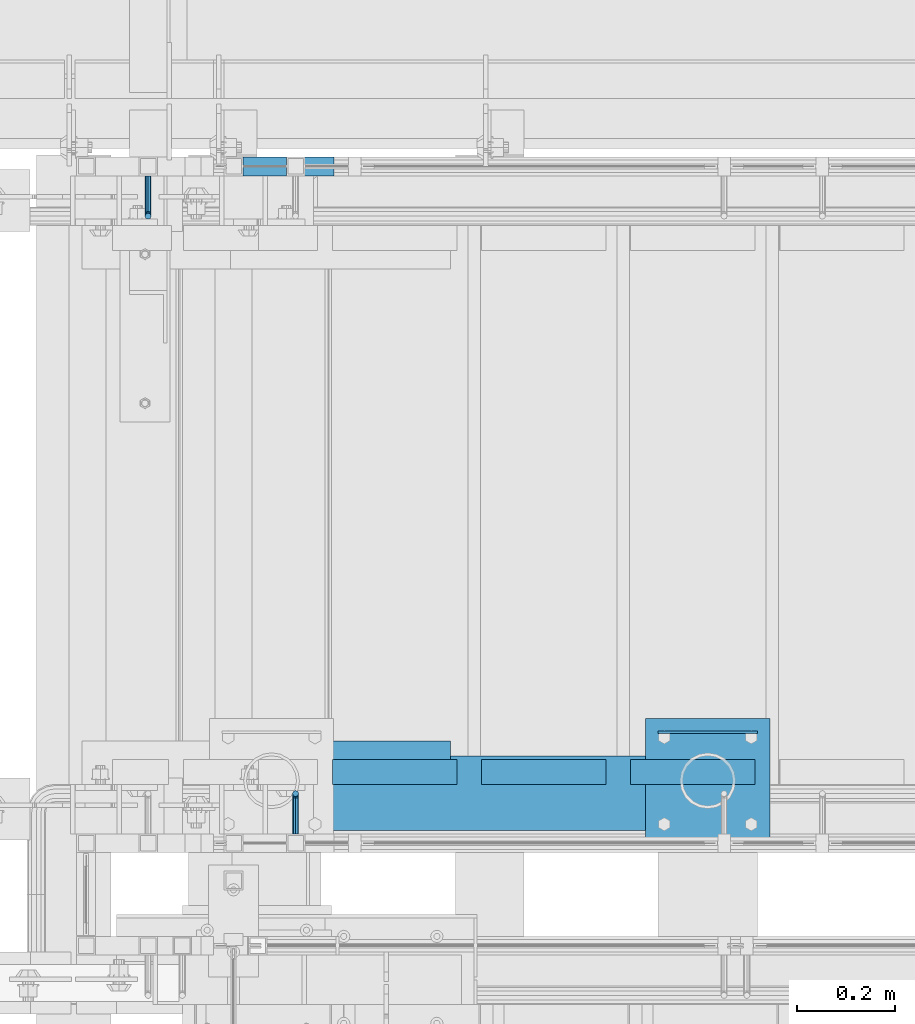
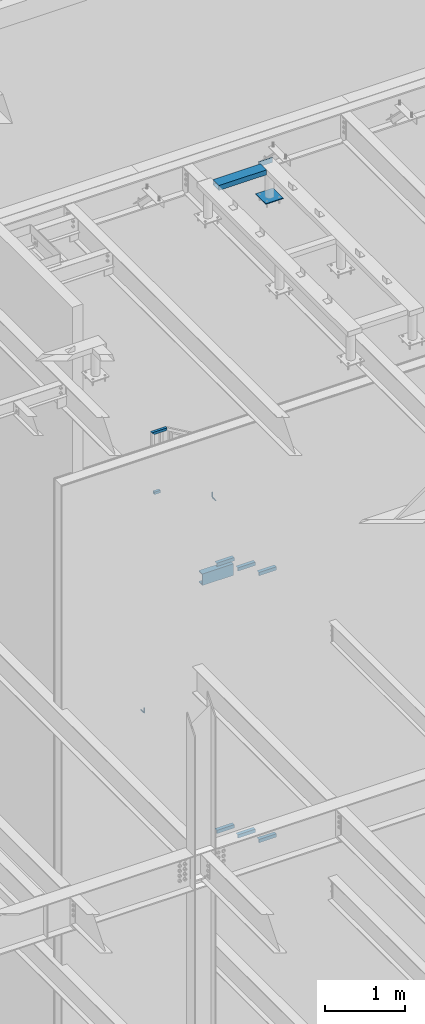
# One storey, part 933 of 1179: 12 beams, 2 members, 6 elements without a shape of their own.
"""IFC2X3 building model written with IfcOpenShell, lengths in millimetres."""

import ifcopenshell
import ifcopenshell.guid

model = None  # the IFC model being written
_history = None  # IfcOwnerHistory: only IFC2X3 demands one
_inside = {}  # id of a spatial element -> (the spatial element, [elements in it])
_under = {}  # id of a project, library or spatial element -> (it, [spatial elements below it])
_declared = {}  # id of a project -> (the project, [libraries it declares])
_typed = {}  # id of a type object -> (the type object, [elements of that type])
_made_of = {}  # id of a material, layer set ... -> (it, [elements and type objects made of it])


def new_model(schema):
    """Start an empty IFC model of exactly this schema.

    Asked for "IFC4X3", IfcOpenShell would pick the latest addendum, in which some entities
    have other attributes; the version numbers below select the first issue.
    IFC2X3 requires an IfcOwnerHistory on every rooted entity: one is made here for all.
    """
    global model, _history
    if schema == "IFC4X3":
        model = ifcopenshell.file(schema_version=(4, 3, 0, 0))
    else:
        model = ifcopenshell.file(schema=schema)
    _inside.clear()
    _under.clear()
    _declared.clear()
    _typed.clear()
    _made_of.clear()
    _history = None
    if model.schema == "IFC2X3":
        org = make("IfcOrganization", Name="unknown")
        user = make(
            "IfcPersonAndOrganization",
            ThePerson=make("IfcPerson", FamilyName="unknown"),
            TheOrganization=org,
        )
        app = make(
            "IfcApplication",
            ApplicationDeveloper=org,
            Version="unknown",
            ApplicationFullName="unknown",
            ApplicationIdentifier="unknown",
        )
        _history = make(
            "IfcOwnerHistory",
            OwningUser=user,
            OwningApplication=app,
            ChangeAction="ADDED",
            CreationDate=0,
        )
    return model


def make(cls, **values):
    """One entity of the class cls with the attributes given. An attribute that is None is left unset."""
    return model.create_entity(
        cls, **{name: value for name, value in values.items() if value is not None}
    )


def rooted(cls, **values):
    """An entity with a GlobalId (a new one), such as an element, a storey or a relation."""
    return make(cls, GlobalId=ifcopenshell.guid.new(), OwnerHistory=_history, **values)


def si_unit(unit_type, name, prefix=None):
    """IfcSIUnit, for example si_unit("LENGTHUNIT", "METRE", prefix="MILLI")."""
    return make("IfcSIUnit", UnitType=unit_type, Prefix=prefix, Name=name)


def assignment(units):
    """IfcUnitAssignment: the units of a project."""
    return None if units is None else make("IfcUnitAssignment", Units=units)


def point(xyz):
    """IfcCartesianPoint."""
    return None if xyz is None else make("IfcCartesianPoint", Coordinates=xyz)


def direction(xyz):
    """IfcDirection."""
    return None if xyz is None else make("IfcDirection", DirectionRatios=xyz)


def frame(location, z_axis=None, x_axis=None):
    """IfcAxis2Placement3D, a coordinate frame: its origin and axes. An axis left out is left unset."""
    return make(
        "IfcAxis2Placement3D",
        Location=point(location),
        Axis=direction(z_axis),
        RefDirection=direction(x_axis),
    )


def origin_with_axes():
    """The frame at (0, 0, 0) with the z axis (0, 0, 1) and the x axis (1, 0, 0) written out."""
    return frame((0.0, 0.0, 0.0), z_axis=(0.0, 0.0, 1.0), x_axis=(1.0, 0.0, 0.0))


def place(relative_to, where):
    """IfcLocalPlacement: puts the frame where relative to a parent placement (None: the world)."""
    return make(
        "IfcLocalPlacement", PlacementRelTo=relative_to, RelativePlacement=where
    )


def context(
    kind, dimensions, precision=None, world=None, true_north=None, identifier=None
):
    """IfcGeometricRepresentationContext, for example the 3D "Model" context."""
    return make(
        "IfcGeometricRepresentationContext",
        ContextIdentifier=identifier,
        ContextType=kind,
        CoordinateSpaceDimension=dimensions,
        Precision=precision,
        WorldCoordinateSystem=world,
        TrueNorth=true_north,
    )


def subcontext(parent, identifier, kind, view, scale=None):
    """IfcGeometricRepresentationSubContext, for example "Body" below "Model"."""
    return make(
        "IfcGeometricRepresentationSubContext",
        ContextIdentifier=identifier,
        ContextType=kind,
        ParentContext=parent,
        TargetScale=scale,
        TargetView=view,
    )


def project(units=None, contexts=None):
    """IfcProject with its units and contexts."""
    return rooted(
        "IfcProject",
        Name="project",
        RepresentationContexts=contexts,
        UnitsInContext=assignment(units),
    )


def spatial(cls, under=None, at=None, **own):
    """A site, building, storey or space (cls), placed at a placement, below another one or the project."""
    s = rooted(cls, ObjectPlacement=at, **own)
    if under is not None:
        _under.setdefault(under.id(), (under, []))[1].append(s)
    return s


def faces_of(points, faces, orient=None, outer=None):
    """IfcFace entities. A face is a list of loops; a loop is a list of indices into points, from 0.

    orient and outer hold one flag for each loop. By default every Orientation is true, the
    first loop of a face is its IfcFaceOuterBound and the others are IfcFaceBound.
    """
    made = []
    for i, loops in enumerate(faces):
        bounds = []
        for j, loop in enumerate(loops):
            is_outer = j == 0 if outer is None else outer[i][j]
            bounds.append(
                make(
                    "IfcFaceOuterBound" if is_outer else "IfcFaceBound",
                    Bound=make("IfcPolyLoop", Polygon=[points[k] for k in loop]),
                    Orientation=True if orient is None else orient[i][j],
                )
            )
        made.append(make("IfcFace", Bounds=bounds))
    return made


def faceted_brep(points, faces, orient=None, outer=None, voids=None):
    """IfcFacetedBrep: a solid bounded by flat faces; with voids (closed shells), ...WithVoids."""
    shared = [point(p) for p in points]
    hull = make("IfcClosedShell", CfsFaces=faces_of(shared, faces, orient, outer))
    if voids is None:
        return make("IfcFacetedBrep", Outer=hull)
    return make(
        "IfcFacetedBrepWithVoids",
        Outer=hull,
        Voids=[
            make(cls, CfsFaces=faces_of(shared, fs, o, b)) for cls, fs, o, b in voids
        ],
    )


def shape(context_of_items, identifier, shape_type, items):
    """IfcShapeRepresentation: the items that make up one representation, for example the "Body"."""
    return make(
        "IfcShapeRepresentation",
        ContextOfItems=context_of_items,
        RepresentationIdentifier=identifier,
        RepresentationType=shape_type,
        Items=items,
    )


def material(Name=None, Category=None):
    """IfcMaterial."""
    return make("IfcMaterial", Name=Name, Category=Category)


def made_of(thing, what):
    """Note that an element or type object is made of a material, layer set ...; save() writes the relation."""
    if what is not None:
        _made_of.setdefault(what.id(), (what, []))[1].append(thing)
    return thing


def type_object(cls, material=None, **own):
    """A type object (cls), such as IfcWallType, which elements share."""
    return made_of(rooted(cls, **own), material)


def element(
    cls,
    number,
    at=None,
    inside=None,
    cuts=None,
    type_object=None,
    material=None,
    context=None,
    identifier="Body",
    shape_type=None,
    held_by="IfcProductDefinitionShape",
    body=None,
    shapes=None,
    **own,
):
    """One element of the class cls, such as IfcWall. Its Tag is "e" and its number.

    at: its placement. inside: the storey or other place that contains it. cuts: it is an
    opening in that element (IfcRelVoidsElement). A single representation is given by context,
    identifier, shape_type and body (its items); several are given by shapes. held_by: the class
    of the entity that holds the representations. save() writes the other relations.
    """
    e = rooted(cls, Tag="e%d" % number, ObjectPlacement=at, **own)
    if body is not None:
        shapes = [shape(context, identifier, shape_type, body)]
    if shapes is not None:
        e.Representation = make(held_by, Representations=shapes)
    if inside is not None:
        _inside.setdefault(inside.id(), (inside, []))[1].append(e)
    if cuts is not None:
        rooted(
            "IfcRelVoidsElement", RelatingBuildingElement=cuts, RelatedOpeningElement=e
        )
    if type_object is not None:
        _typed.setdefault(type_object.id(), (type_object, []))[1].append(e)
    return made_of(e, material)


def aggregate(whole, parts):
    """IfcRelAggregates: a whole, such as a stair, and the parts it consists of."""
    return rooted("IfcRelAggregates", RelatingObject=whole, RelatedObjects=parts)


def save(model, path):
    """Write the relations noted so far, then the file.

    IfcRelAggregates (storeys below a building ...), IfcRelContainedInSpatialStructure (elements
    in a storey), IfcRelDefinesByType, IfcRelAssociatesMaterial and IfcRelDeclares: one each for
    every whole, place, type object, material and project.
    """
    for whole, parts in _under.values():
        aggregate(whole, parts)
    for where, things in _inside.values():
        rooted(
            "IfcRelContainedInSpatialStructure",
            RelatedElements=things,
            RelatingStructure=where,
        )
    for kind, things in _typed.values():
        rooted("IfcRelDefinesByType", RelatedObjects=things, RelatingType=kind)
    for what, things in _made_of.values():
        rooted("IfcRelAssociatesMaterial", RelatedObjects=things, RelatingMaterial=what)
    for by, libraries in _declared.values():
        rooted("IfcRelDeclares", RelatingContext=by, RelatedDefinitions=libraries)
    model.write(path)


model = new_model("IFC2X3")

# Units and contexts
model_context = context("Model", 3, precision=1e-05, world=origin_with_axes())
body_context = subcontext(model_context, "Body", "Model", "MODEL_VIEW")
ifc_project = project(units=[si_unit("LENGTHUNIT", "METRE", prefix="MILLI"), si_unit("AREAUNIT", "SQUARE_METRE"), si_unit("VOLUMEUNIT", "CUBIC_METRE"), si_unit("MASSUNIT", "GRAM", prefix="KILO"), si_unit("TIMEUNIT", "SECOND"), si_unit("PLANEANGLEUNIT", "RADIAN"), si_unit("SOLIDANGLEUNIT", "STERADIAN"), si_unit("THERMODYNAMICTEMPERATUREUNIT", "DEGREE_CELSIUS"), si_unit("LUMINOUSINTENSITYUNIT", "LUMEN")], contexts=[model_context])

# Site, building, storey
site_placement = place(None, origin_with_axes())
site = spatial("IfcSite", under=ifc_project, at=site_placement, CompositionType="ELEMENT")
building_placement = place(site_placement, origin_with_axes())
building = spatial("IfcBuilding", under=site, at=building_placement, Name="Undefined", CompositionType="ELEMENT")
storey_placement = place(building_placement, origin_with_axes())
storey = spatial("IfcBuildingStorey", under=building, at=storey_placement, Name="Undefined", CompositionType="ELEMENT", Elevation=0.0)

# Assembly, members
assembly_1_placement = place(storey_placement, origin_with_axes())
assembly_1 = element("IfcElementAssembly", 1, at=assembly_1_placement, inside=storey, Name="GUARDRAIL", AssemblyPlace="NOTDEFINED", PredefinedType="RIGID_FRAME")
ifc_material_1 = material()
member_type = type_object("IfcMemberType", Name="HSS1-1/2X1-1/2X1/8", PredefinedType="NOTDEFINED")
member_1_placement = place(assembly_1_placement, frame((19605.6249994667, 41065.449999238, 8293.0999995645), z_axis=(0.0, -1.0, 0.0), x_axis=(1.0, 0.0, 0.0)))
member_1 = element("IfcMember", 2, at=member_1_placement, type_object=member_type, material=ifc_material_1, Name="BOTTOM_RAIL", ObjectType="HSS1-1/2X1-1/2X1/8", context=body_context, shape_type="Brep", body=[
    faceted_brep([(19.0499999999993, 15.8749992829999, -15.874999282998), (19.0499999999993, -15.8749992829999, -15.874999282998), (107.950001288671, -15.8749992829944, -15.874999282998), (107.950001161731, 15.8749992830053, -15.874999282998), (19.0499999999993, -15.8749992829999, 15.874999282998), (107.950001288671, -15.8749992829944, 15.874999282998), (19.0499999999993, 15.8749992829999, 15.874999282998), (107.950001161731, 15.8749992830053, 15.874999282998), (107.949999235003, 19.0499992349996, 19.0499992350015), (107.949999235003, 19.0499992349996, -19.0499992350015), (19.0499999999993, 19.0499992349996, -19.0499992350015), (19.0499999999993, 19.0499992349996, 19.0499992350015), (19.0499999999993, -19.0499992349996, 19.0500001223481), (107.950001301364, -19.0499992349942, 19.0499992350015), (19.0499999999993, -19.0499992349996, -19.0499992350015), (107.950001301364, -19.0499992349942, -19.0499992350015)], [[[0, 1, 2, 3]], [[1, 4, 5, 2]], [[4, 6, 7, 5]], [[6, 0, 3, 7]], [[8, 9, 10, 11]], [[11, 12, 13, 8]], [[12, 14, 15, 13]], [[14, 10, 9, 15]], [[13, 15, 9, 8], [5, 7, 3, 2]], [[12, 11, 10, 14], [4, 1, 0, 6]]]),
])
member_2_placement = place(assembly_1_placement, frame((19605.6249991619, 41065.449999238, 9213.85000000737), z_axis=(0.0, 0.0, 1.0), x_axis=(1.0, 0.0, 0.0)))
member_2 = element("IfcMember", 3, at=member_2_placement, type_object=member_type, material=ifc_material_1, Name="TOP_RAIL", ObjectType="HSS1-1/2X1-1/2X1/8", context=body_context, shape_type="Brep", body=[
    faceted_brep([(15.874999282998, 15.874999282998, -15.8749992829999), (15.874999282998, -15.874999282998, -15.8749992829999), (195.733208365273, -15.874999282998, -15.8749992829999), (195.733208365273, 15.874999282998, -15.8749992829999), (-15.8749992830017, -15.874999282998, 15.8749992829999), (204.316793203543, -15.874999282998, 15.8749992829999), (-15.8749992830017, 15.874999282998, 15.8749992829999), (204.316793203543, 15.874999282998, 15.8749992829999), (19.0499999999993, 19.0499992349996, -19.0499992350015), (-19.0499992350015, 19.0499992350015, 19.0499992349996), (205.175151713163, 19.0499992350015, 19.0499992349996), (194.874849855652, 19.0499992350015, -19.0499992349996), (-19.0499992350015, -19.0499992350015, 19.0499992349996), (205.175151713163, -19.0499992350015, 19.0499992349996), (19.0499999999993, -19.0499992349996, -19.0499992350015), (194.874849855652, -19.0499992350015, -19.0499992349996)], [[[0, 1, 2, 3]], [[1, 4, 5, 2]], [[4, 6, 7, 5]], [[6, 0, 3, 7]], [[8, 9, 10, 11]], [[9, 12, 13, 10]], [[12, 14, 15, 13]], [[14, 8, 11, 15]], [[13, 15, 11, 10], [5, 7, 3, 2]], [[14, 12, 9, 8], [6, 4, 1, 0]]]),
])
aggregate(assembly_1, [member_1, member_2])

# Assembly, beams
assembly_2_placement = place(storey_placement, origin_with_axes())
assembly_2 = element("IfcElementAssembly", 4, at=assembly_2_placement, inside=storey, Name="STAIR", AssemblyPlace="NOTDEFINED", PredefinedType="RIGID_FRAME")
ifc_material_2 = material(Name="STEEL/A36")
beam_type_1 = type_object("IfcBeamType", Name="L2X2X3/16", PredefinedType="NOTDEFINED")
beam_1_placement = place(assembly_2_placement, frame((20062.4321735296, 39827.2000000447, 3803.71613283764), z_axis=(0.0, 1.0, 0.0), x_axis=(-1.0, 0.0, 0.0)))
beam_1 = element("IfcBeam", 5, at=beam_1_placement, type_object=beam_type_1, material=ifc_material_2, Name="ANGLE", ObjectType="L2X2X3/16", context=body_context, shape_type="Brep", body=[
    faceted_brep([(0.0, 25.3999999999996, -25.4000000000015), (0.0, 25.3999999999996, 25.4000000000015), (254.0, 25.3999999999996, 25.4000000000001), (254.0, 25.3999999999996, -25.4000000000001), (0.0, 20.6374999999998, 25.4000000000015), (254.0, 20.6374999999998, 25.4000000000001), (0.0, 20.6374999999998, -20.6374999999971), (254.0, 20.6374999999998, -20.6374999999998), (0.0, -25.3999999999996, -20.6374999999971), (254.0, -25.3999999999996, -20.6374999999998), (0.0, -25.3999999999996, -25.4000000000015), (254.0, -25.3999999999996, -25.4000000000001)], [[[0, 1, 2, 3]], [[1, 4, 5, 2]], [[4, 6, 7, 5]], [[6, 8, 9, 7]], [[8, 10, 11, 9]], [[10, 0, 3, 11]], [[5, 7, 9, 11, 3, 2]], [[10, 8, 6, 4, 1, 0]]]),
])
beam_2_placement = place(assembly_2_placement, frame((20367.2321735222, 39827.2000000425, 3627.23904955393), z_axis=(0.0, 1.0, 0.0), x_axis=(-1.0, 0.0, 0.0)))
beam_2 = element("IfcBeam", 6, at=beam_2_placement, type_object=beam_type_1, material=ifc_material_2, Name="ANGLE", ObjectType="L2X2X3/16", context=body_context, shape_type="Brep", body=[
    faceted_brep([(0.0, 25.3999999999996, -25.4000000000015), (0.0, 25.3999999999996, 25.4000000000015), (254.0, 25.3999999999996, 25.4000000000001), (254.0, 25.3999999999996, -25.4000000000001), (0.0, 20.6374999999998, 25.4000000000015), (254.0, 20.6374999999998, 25.4000000000001), (0.0, 20.6374999999998, -20.6374999999971), (254.0, 20.6374999999998, -20.6374999999998), (0.0, -25.3999999999996, -20.6374999999971), (254.0, -25.3999999999996, -20.6374999999998), (0.0, -25.3999999999996, -25.4000000000015), (254.0, -25.3999999999996, -25.4000000000001)], [[[0, 1, 2, 3]], [[1, 4, 5, 2]], [[4, 6, 7, 5]], [[6, 8, 9, 7]], [[8, 10, 11, 9]], [[10, 0, 3, 11]], [[5, 7, 9, 11, 3, 2]], [[10, 8, 6, 4, 1, 0]]]),
])
beam_3_placement = place(assembly_2_placement, frame((20672.0321735147, 39827.2000000403, 3450.76196627022), z_axis=(0.0, 1.0, 0.0), x_axis=(-1.0, 0.0, 0.0)))
beam_3 = element("IfcBeam", 7, at=beam_3_placement, type_object=beam_type_1, material=ifc_material_2, Name="ANGLE", ObjectType="L2X2X3/16", context=body_context, shape_type="Brep", body=[
    faceted_brep([(0.0, 25.3999999999996, -25.4000000000015), (0.0, 25.3999999999996, 25.4000000000015), (254.0, 25.3999999999996, 25.4000000000001), (254.0, 25.3999999999996, -25.4000000000001), (0.0, 20.6374999999998, 25.4000000000015), (254.0, 20.6374999999998, 25.4000000000001), (0.0, 20.6374999999998, -20.6374999999971), (254.0, 20.6374999999998, -20.6374999999998), (0.0, -25.3999999999996, -20.6374999999971), (254.0, -25.3999999999996, -20.6374999999998), (0.0, -25.3999999999996, -25.4000000000015), (254.0, -25.3999999999996, -25.4000000000001)], [[[0, 1, 2, 3]], [[1, 4, 5, 2]], [[4, 6, 7, 5]], [[6, 8, 9, 7]], [[8, 10, 11, 9]], [[10, 0, 3, 11]], [[5, 7, 9, 11, 3, 2]], [[10, 8, 6, 4, 1, 0]]]),
])
aggregate(assembly_2, [beam_1, beam_2, beam_3])

assembly_3_placement = place(storey_placement, origin_with_axes())
assembly_3 = element("IfcElementAssembly", 8, at=assembly_3_placement, inside=storey, Name="STAIR", AssemblyPlace="NOTDEFINED", PredefinedType="RIGID_FRAME")
beam_4_placement = place(assembly_3_placement, frame((20062.4869692969, 39827.2000000125, 7890.47030000811), z_axis=(0.0, 1.0, 0.0), x_axis=(-1.0, 0.0, 0.0)))
beam_4 = element("IfcBeam", 9, at=beam_4_placement, type_object=beam_type_1, material=ifc_material_2, Name="ANGLE", ObjectType="L2X2X3/16", context=body_context, shape_type="Brep", body=[
    faceted_brep([(0.0, 25.3999999999996, -25.4000000000015), (0.0, 25.3999999999996, 25.4000000000015), (254.0, 25.3999999999996, 25.4000000000001), (254.0, 25.3999999999996, -25.4000000000001), (0.0, 20.6374999999998, 25.4000000000015), (254.0, 20.6374999999998, 25.4000000000001), (0.0, 20.6374999999998, -20.6374999999971), (254.0, 20.6374999999998, -20.6374999999998), (0.0, -25.3999999999996, -20.6374999999971), (254.0, -25.3999999999996, -20.6374999999998), (0.0, -25.3999999999996, -25.4000000000015), (254.0, -25.3999999999996, -25.4000000000001)], [[[0, 1, 2, 3]], [[1, 4, 5, 2]], [[4, 6, 7, 5]], [[6, 8, 9, 7]], [[8, 10, 11, 9]], [[10, 0, 3, 11]], [[5, 7, 9, 11, 3, 2]], [[10, 8, 6, 4, 1, 0]]]),
])
beam_5_placement = place(assembly_3_placement, frame((20367.2869690449, 39827.2000000125, 7712.67030000811), z_axis=(0.0, 1.0, 0.0), x_axis=(-1.0, 0.0, 0.0)))
beam_5 = element("IfcBeam", 10, at=beam_5_placement, type_object=beam_type_1, material=ifc_material_2, Name="ANGLE", ObjectType="L2X2X3/16", context=body_context, shape_type="Brep", body=[
    faceted_brep([(0.0, 25.3999999999996, -25.4000000000015), (0.0, 25.3999999999996, 25.4000000000015), (254.0, 25.3999999999996, 25.4000000000001), (254.0, 25.3999999999996, -25.4000000000001), (0.0, 20.6374999999998, 25.4000000000015), (254.0, 20.6374999999998, 25.4000000000001), (0.0, 20.6374999999998, -20.6374999999971), (254.0, 20.6374999999998, -20.6374999999998), (0.0, -25.3999999999996, -20.6374999999971), (254.0, -25.3999999999996, -20.6374999999998), (0.0, -25.3999999999996, -25.4000000000015), (254.0, -25.3999999999996, -25.4000000000001)], [[[0, 1, 2, 3]], [[1, 4, 5, 2]], [[4, 6, 7, 5]], [[6, 8, 9, 7]], [[8, 10, 11, 9]], [[10, 0, 3, 11]], [[5, 7, 9, 11, 3, 2]], [[10, 8, 6, 4, 1, 0]]]),
])
beam_6_placement = place(assembly_3_placement, frame((20672.0869687928, 39827.2000000125, 7534.87030000811), z_axis=(0.0, 1.0, 0.0), x_axis=(-1.0, 0.0, 0.0)))
beam_6 = element("IfcBeam", 11, at=beam_6_placement, type_object=beam_type_1, material=ifc_material_2, Name="ANGLE", ObjectType="L2X2X3/16", context=body_context, shape_type="Brep", body=[
    faceted_brep([(0.0, 25.3999999999996, -25.4000000000015), (0.0, 25.3999999999996, 25.4000000000015), (254.0, 25.3999999999996, 25.4000000000001), (254.0, 25.3999999999996, -25.4000000000001), (0.0, 20.6374999999998, 25.4000000000015), (254.0, 20.6374999999998, 25.4000000000001), (0.0, 20.6374999999998, -20.6374999999971), (254.0, 20.6374999999998, -20.6374999999998), (0.0, -25.3999999999996, -20.6374999999971), (254.0, -25.3999999999996, -20.6374999999998), (0.0, -25.3999999999996, -25.4000000000015), (254.0, -25.3999999999996, -25.4000000000001)], [[[0, 1, 2, 3]], [[1, 4, 5, 2]], [[4, 6, 7, 5]], [[6, 8, 9, 7]], [[8, 10, 11, 9]], [[10, 0, 3, 11]], [[5, 7, 9, 11, 3, 2]], [[10, 8, 6, 4, 1, 0]]]),
])

# Assembly, beam
assembly_4_placement = place(storey_placement, origin_with_axes())
assembly_4 = element("IfcElementAssembly", 12, at=assembly_4_placement, inside=storey, Name="GUARDRAIL", AssemblyPlace="NOTDEFINED", PredefinedType="RIGID_FRAME")
beam_type_2 = type_object("IfcBeamType", PredefinedType="NOTDEFINED")
beam_7_placement = place(assembly_4_placement, frame((19430.8919387852, 41046.3999992077, 5054.60000002879), z_axis=(0.0, 0.0, 1.0), x_axis=(0.0, -1.0, 0.0)))
beam_7 = element("IfcBeam", 13, at=beam_7_placement, type_object=beam_type_2, material=ifc_material_2, Name="BRACKET", context=body_context, shape_type="Brep", body=[
    faceted_brep([(0.0, -4.49012806053361, 4.49012806053452), (0.0, 0.0, 6.34999999999991), (0.0, 4.49012806053361, 4.49012806053452), (0.0, 6.34999999999854, 0.0), (0.0, 4.49012806053361, -4.49012806053452), (0.0, 0.0, -6.34999999999991), (0.0, -4.49012806053361, -4.49012806053452), (0.0, -6.34999999999854, 0.0), (69.849999425729, 0.0, -6.34999999999991), (69.849999425729, -4.49012806053361, -4.49012806053452), (69.849999425729, -6.34999999999854, 0.0), (69.849999425729, -4.49012806053361, 4.49012806053452), (69.849999425729, 0.0, 6.34999999999991), (69.849999425729, 4.49012806053361, 4.49012806053452), (69.849999425729, 6.34999999999854, 0.0), (69.849999425729, 4.49012806053361, -4.49012806053452), (78.445063360632, 4.49012806053361, -2.18708762028064), (79.3749993303718, 0.0, -3.79778396764323), (78.445063360632, -4.49012806053361, -2.18708762028064), (76.1999993303689, -6.34999999999854, 1.70147734638658), (73.9549353000984, -4.49012806053361, 5.59004231305425), (73.024999330366, 0.0, 7.20073866041639), (73.9549353000984, 4.49012806053361, 5.59004231305425), (76.1999993303689, 6.34999999999854, 1.70147734638658), (80.8485218886053, 6.34999999999854, 6.34999990462893), (84.7370868552753, 4.49012806053361, 4.10493587436031), (76.9599569219426, 4.49012806053361, 8.59506393489755), (75.3492605745778, 0.0, 9.52499990463093), (76.9599569219426, -4.49012806053361, 8.59506393489755), (80.8485218886053, -6.34999999999854, 6.34999990462893), (84.7370868552753, -4.49012806053361, 4.10493587436031), (86.3477832026401, 0.0, 3.17499990462693), (87.0401272955278, 4.49012806053361, 12.6999998092651), (88.8999992349927, 0.0, 12.6999998092651), (82.5499992349942, 6.34999999999854, 12.6999998092651), (78.0598711744606, 4.49012806053361, 12.6999998092651), (76.1999992349956, 0.0, 12.6999998092651), (78.0598711744606, -4.49012806053361, 12.6999998092651), (82.5499992349942, -6.34999999999854, 12.6999998092651), (87.0401272955278, -4.49012806053361, 12.6999998092651), (88.8999992349927, 0.0, 76.2000000000003), (87.0401272955278, -4.49012806053361, 76.2000000000007), (82.5499992349942, -6.34999999999854, 76.2000000000007), (78.0598711744606, -4.49012806053361, 76.2000000000007), (76.1999992349956, 0.0, 76.2000000000003), (78.0598711744606, 4.49012806053361, 76.2000000000007), (82.5499992349942, 6.34999999999854, 76.2000000000007), (87.0401272955278, 4.49012806053361, 76.2000000000007)], [[[0, 1, 2, 3, 4, 5, 6, 7]], [[6, 5, 8, 9]], [[7, 6, 9, 10]], [[0, 7, 10, 11]], [[1, 0, 11, 12]], [[2, 1, 12, 13]], [[3, 2, 13, 14]], [[4, 3, 14, 15]], [[5, 4, 15, 8]], [[8, 15, 16, 17]], [[9, 8, 17, 18]], [[10, 9, 18, 19]], [[11, 10, 19, 20]], [[12, 11, 20, 21]], [[13, 12, 21, 22]], [[14, 13, 22, 23]], [[15, 14, 23, 16]], [[23, 24, 25, 16]], [[22, 26, 24, 23]], [[21, 27, 26, 22]], [[20, 28, 27, 21]], [[19, 29, 28, 20]], [[18, 30, 29, 19]], [[17, 31, 30, 18]], [[16, 25, 31, 17]], [[25, 32, 33, 31]], [[24, 34, 32, 25]], [[26, 35, 34, 24]], [[27, 36, 35, 26]], [[28, 37, 36, 27]], [[29, 38, 37, 28]], [[30, 39, 38, 29]], [[31, 33, 39, 30]], [[39, 33, 40, 41]], [[38, 39, 41, 42]], [[37, 38, 42, 43]], [[36, 37, 43, 44]], [[35, 36, 44, 45]], [[34, 35, 45, 46]], [[32, 34, 46, 47]], [[33, 32, 47, 40]], [[40, 47, 46, 45, 44, 43, 42, 41]]]),
])
aggregate(assembly_4, [beam_7])

assembly_5_placement = place(storey_placement, origin_with_axes())
assembly_5 = element("IfcElementAssembly", 14, at=assembly_5_placement, inside=storey, Name="GUARDRAIL", AssemblyPlace="NOTDEFINED", PredefinedType="RIGID_FRAME")
beam_8_placement = place(assembly_5_placement, frame((19732.6249999269, 39700.2000007796, 8966.2), z_axis=(0.0, 0.0, 1.0), x_axis=(0.0, 1.0, 0.0)))
beam_8 = element("IfcBeam", 15, at=beam_8_placement, type_object=beam_type_2, material=ifc_material_2, Name="BRACKET", context=body_context, shape_type="Brep", body=[
    faceted_brep([(0.0, -6.34999999999854, 0.0), (0.0, -4.49012806053361, -4.49012806053452), (69.849999425729, -4.49012806053361, -4.49012806053452), (69.849999425729, -6.34999999999854, 0.0), (0.0, 0.0, -6.34999999999991), (69.849999425729, 0.0, -6.34999999999991), (0.0, 4.49012806053361, -4.49012806053452), (69.849999425729, 4.49012806053361, -4.49012806053452), (0.0, 6.34999999999854, 0.0), (69.849999425729, 6.34999999999854, 0.0), (0.0, 4.49012806053361, 4.49012806053452), (69.849999425729, 4.49012806053361, 4.49012806053452), (0.0, 0.0, 6.34999999999991), (69.849999425729, 0.0, 6.34999999999991), (0.0, -4.49012806053361, 4.49012806053452), (69.849999425729, -4.49012806053361, 4.49012806053452), (79.3749993303718, 0.0, -3.79778396764323), (78.445063360632, -4.49012806053361, -2.18708762028064), (76.1999993303689, -6.34999999999854, 1.70147734638658), (73.9549353000984, -4.49012806053361, 5.59004231305425), (73.024999330366, 0.0, 7.20073866041639), (73.9549353000984, 4.49012806053361, 5.59004231305425), (76.1999993303689, 6.34999999999854, 1.70147734638658), (78.445063360632, 4.49012806053361, -2.18708762028064), (84.7370868552753, 4.49012806053361, 4.10493587436031), (86.3477832026401, 0.0, 3.17499990462693), (80.8485218886053, 6.34999999999854, 6.34999990462893), (76.9599569219426, 4.49012806053361, 8.59506393489755), (75.3492605745778, 0.0, 9.52499990463093), (76.9599569219426, -4.49012806053361, 8.59506393489755), (80.8485218886053, -6.34999999999854, 6.34999990462893), (84.7370868552753, -4.49012806053361, 4.10493587436031), (87.0401272955278, 4.49012806053361, 12.6999998092651), (88.8999992349927, 0.0, 12.6999998092651), (82.5499992349942, 6.34999999999854, 12.6999998092651), (78.0598711744606, 4.49012806053361, 12.6999998092651), (76.1999992349956, 0.0, 12.6999998092651), (78.0598711744606, -4.49012806053361, 12.6999998092651), (82.5499992349942, -6.34999999999854, 12.6999998092651), (87.0401272955278, -4.49012806053361, 12.6999998092651), (87.0401272955278, -4.49012806053361, 76.2000000000007), (82.5499992349942, -6.34999999999854, 76.2000000000007), (88.8999992349927, 0.0, 76.2000000000003), (87.0401272955278, 4.49012806053361, 76.2000000000007), (82.5499992349942, 6.34999999999854, 76.2000000000007), (78.0598711744606, 4.49012806053361, 76.2000000000007), (76.1999992349956, 0.0, 76.2000000000003), (78.0598711744606, -4.49012806053361, 76.2000000000007)], [[[0, 1, 2, 3]], [[1, 4, 5, 2]], [[4, 6, 7, 5]], [[6, 8, 9, 7]], [[8, 10, 11, 9]], [[10, 12, 13, 11]], [[12, 14, 15, 13]], [[14, 0, 3, 15]], [[14, 12, 10, 8, 6, 4, 1, 0]], [[2, 5, 16, 17]], [[3, 2, 17, 18]], [[15, 3, 18, 19]], [[13, 15, 19, 20]], [[11, 13, 20, 21]], [[9, 11, 21, 22]], [[7, 9, 22, 23]], [[5, 7, 23, 16]], [[23, 24, 25, 16]], [[22, 26, 24, 23]], [[21, 27, 26, 22]], [[20, 28, 27, 21]], [[19, 29, 28, 20]], [[18, 30, 29, 19]], [[17, 31, 30, 18]], [[16, 25, 31, 17]], [[24, 32, 33, 25]], [[26, 34, 32, 24]], [[27, 35, 34, 26]], [[28, 36, 35, 27]], [[29, 37, 36, 28]], [[30, 38, 37, 29]], [[31, 39, 38, 30]], [[25, 33, 39, 31]], [[38, 39, 40, 41]], [[39, 33, 42, 40]], [[33, 32, 43, 42]], [[32, 34, 44, 43]], [[34, 35, 45, 44]], [[35, 36, 46, 45]], [[36, 37, 47, 46]], [[37, 38, 41, 47]], [[42, 43, 44, 45, 46, 47, 41, 40]]]),
])
aggregate(assembly_5, [beam_8])

assembly_6_placement = place(storey_placement, origin_with_axes())
assembly_6 = element("IfcElementAssembly", 16, at=assembly_6_placement, inside=storey, Name="FRAME", AssemblyPlace="NOTDEFINED", PredefinedType="RIGID_FRAME")
beam_type_3 = type_object("IfcBeamType", PredefinedType="NOTDEFINED")
beam_9_placement = place(assembly_6_placement, frame((20473.9875, 39908.2415542222, 13722.35), z_axis=(0.0, 0.0, 1.0), x_axis=(1.0, 0.0, 0.0)))
beam_9 = element("IfcBeam", 17, at=beam_9_placement, type_object=beam_type_3, material=ifc_material_2, Name="PLATE", context=body_context, shape_type="Brep", body=[
    faceted_brep([(0.0, 2.38149999999951, -38.0999999999985), (0.0, 2.38149999999951, 38.0999999999985), (203.199999999997, 2.38150000000314, 38.1000000000004), (203.199999999997, 2.38150000000314, -38.1000000000004), (0.0, -2.38149999999951, 38.0999999999985), (203.199999999997, -2.38150000000314, 38.1000000000004), (0.0, -2.38149999999951, -38.0999999999985), (203.199999999997, -2.38150000000314, -38.1000000000004)], [[[0, 1, 2, 3]], [[1, 4, 5, 2]], [[4, 6, 7, 5]], [[6, 0, 3, 7]], [[5, 7, 3, 2]], [[6, 4, 1, 0]]]),
])

# Beam
beam_type_4 = type_object("IfcBeamType", Name="MC7X19.1", PredefinedType="NOTDEFINED")
beam_10_placement = place(assembly_3_placement, frame((19600.126308587, 39846.2500000288, 7735.8875), z_axis=(0.0, 0.0, -1.0), x_axis=(1.0, 0.0, 0.0)))
beam_10 = element("IfcBeam", 18, at=beam_10_placement, type_object=beam_type_4, material=ifc_material_2, Name="BEAM", ObjectType="MC7X19.1", context=body_context, shape_type="Brep", body=[
    faceted_brep([(-0.851308586949017, 44.4499999999971, -88.8999999999996), (-0.851308586949017, 44.4499999999971, 88.8999999999996), (449.289421374284, 44.4499999999971, 88.8999999999996), (449.289421374284, 44.4499999999971, -88.8999999999996), (-0.851308586949017, -44.4499999999971, 88.8999999999996), (449.289421374284, -44.4499999999971, 88.8999999999996), (-0.851308586949017, -44.4499999999971, 77.0845550000004), (449.289421374284, -44.4499999999971, 77.0845550000004), (-0.851308586949017, 34.9250000000029, 75.5049925000003), (449.289421374284, 34.9250000000029, 75.5049925000003), (-0.851308586949017, 34.9250000000029, -75.5049925000003), (449.289421374284, 34.9250000000029, -75.5049925000003), (-0.851308586949017, -44.4499999999971, -77.0845550000004), (449.289421374284, -44.4499999999971, -77.0845550000004), (-0.851308586949017, -44.4499999999971, -88.8999999999996), (449.289421374284, -44.4499999999971, -88.8999999999996)], [[[0, 1, 2, 3]], [[1, 4, 5, 2]], [[4, 6, 7, 5]], [[6, 8, 9, 7]], [[8, 10, 11, 9]], [[10, 12, 13, 11]], [[12, 14, 15, 13]], [[14, 0, 3, 15]], [[5, 7, 9, 11, 13, 15, 3, 2]], [[14, 12, 10, 8, 6, 4, 1, 0]]]),
])

aggregate(assembly_3, [beam_10, beam_4, beam_5, beam_6])

beam_type_5 = type_object("IfcBeamType", Name="HSS6X3X1/4", PredefinedType="NOTDEFINED")
beam_11_placement = place(assembly_6_placement, frame((19785.0125, 39783.6225542222, 13722.35), z_axis=(0.0, -1.0, 0.0), x_axis=(1.0, 0.0, 0.0)))
beam_11 = element("IfcBeam", 19, at=beam_11_placement, type_object=beam_type_5, material=ifc_material_1, Name="BEAM", ObjectType="HSS6X3X1/4", context=body_context, shape_type="Brep", body=[
    faceted_brep([(0.0, 31.75, -69.8499999999985), (0.0, -31.75, -69.8499999999985), (688.975000000006, -31.75, -69.8499999999985), (688.975000000006, 31.75, -69.8499999999985), (0.0, -31.75, 69.8499999999985), (688.975000000006, -31.75, 69.8499999999985), (0.0, 31.75, 69.8499999999985), (688.975000000006, 31.75, 69.8499999999985), (0.0, 38.0999999999985, -76.1999999999998), (0.0, 38.0999999999985, 76.1999999999998), (688.975000000006, 38.1000000000004, 76.1999999999971), (688.975000000006, 38.1000000000004, -76.1999999999971), (0.0, -38.0999999999985, 76.1999999999998), (688.975000000006, -38.1000000000004, 76.1999999999971), (0.0, -38.0999999999985, -76.1999999999998), (688.975000000006, -38.1000000000004, -76.1999999999971)], [[[0, 1, 2, 3]], [[1, 4, 5, 2]], [[4, 6, 7, 5]], [[6, 0, 3, 7]], [[8, 9, 10, 11]], [[9, 12, 13, 10]], [[12, 14, 15, 13]], [[14, 8, 11, 15]], [[13, 15, 11, 10], [5, 7, 3, 2]], [[14, 12, 9, 8], [6, 4, 1, 0]]]),
])

beam_type_6 = type_object("IfcBeamType", PredefinedType="NOTDEFINED")
beam_12_placement = place(assembly_6_placement, frame((20575.5875, 39682.0225542222, 13258.8), z_axis=(1.0, 0.0, 0.0), x_axis=(0.0, 1.0, 0.0)))
beam_12 = element("IfcBeam", 20, at=beam_12_placement, type_object=beam_type_6, material=ifc_material_2, Name="PLATE", context=body_context, shape_type="Brep", body=[
    faceted_brep([(0.0, 6.35000000000036, -127.0), (0.0, 6.34999999999854, 127.0), (254.0, 6.35000000000036, 127.0), (254.0, 6.35000000000036, -127.0), (0.0, -6.34999999999854, 127.0), (254.0, -6.35000000000036, 127.0), (0.0, -6.35000000000036, -127.0), (254.0, -6.35000000000036, -127.0)], [[[0, 1, 2, 3]], [[1, 4, 5, 2]], [[4, 6, 7, 5]], [[6, 0, 3, 7]], [[5, 7, 3, 2]], [[6, 4, 1, 0]]]),
])

aggregate(assembly_6, [beam_11, beam_9, beam_12])

save(model, "model.ifc")
